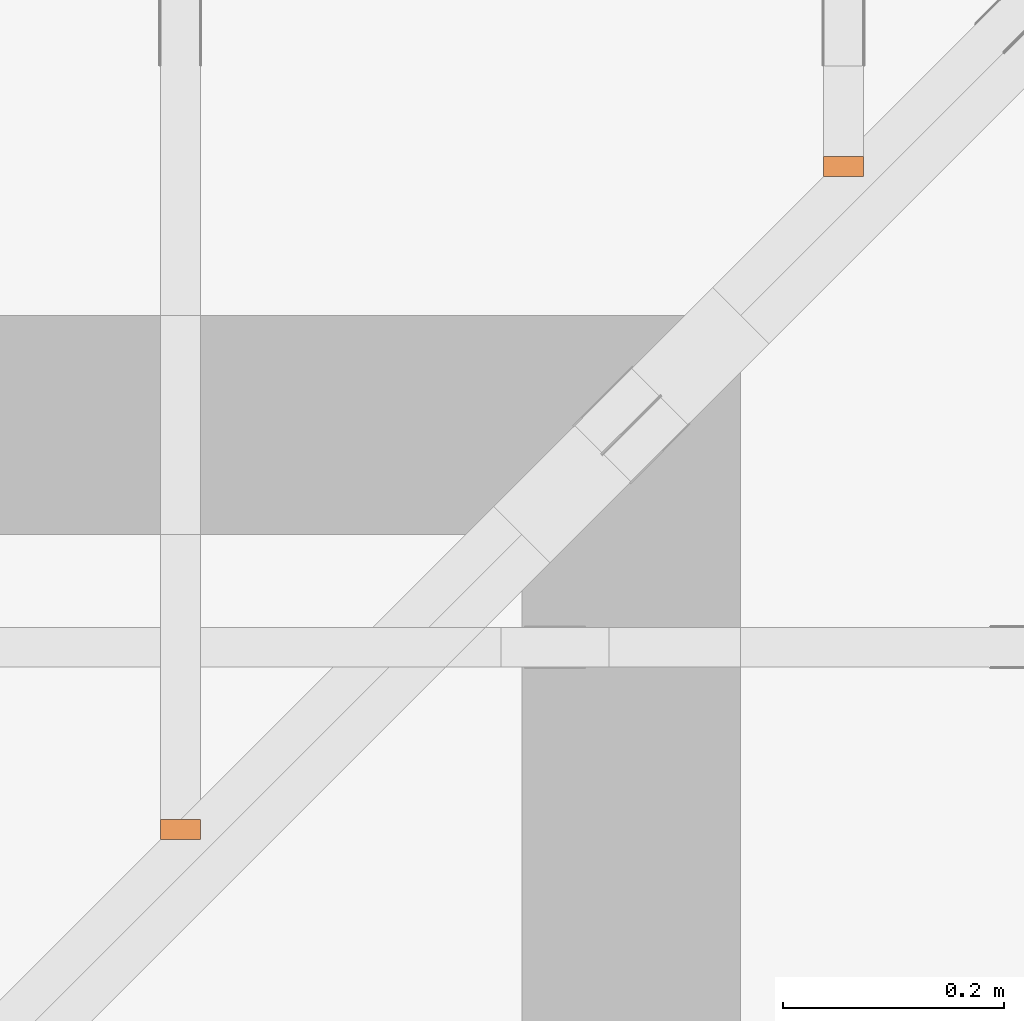
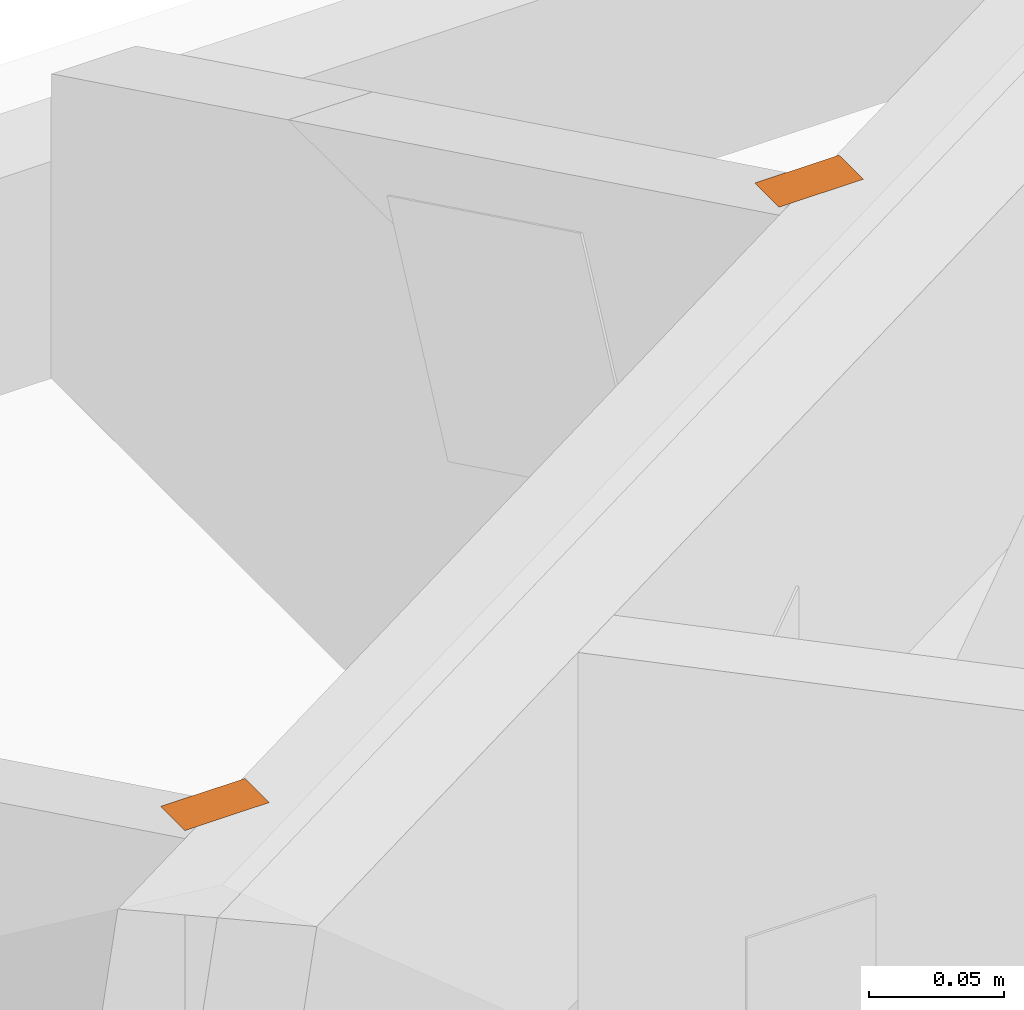
# One storey, part 158 of 159: 2 proxies, 2 elements without a shape of their own.
"""IFC2X3 building model written with IfcOpenShell, lengths in millimetres."""

from ifc_helpers import new_model, si_unit, frame, origin, origin_with_axes, origin_2d, place, context, project, spatial, open_shell, surface_model, element, aggregate, save


model = new_model("IFC2X3")

# Units and contexts
model_context = context("Model", 3, precision=1e-05, world=origin())
plan_context = context("Plan", 2, precision=1e-05, world=origin_2d())
ifc_project = project(units=[si_unit("LENGTHUNIT", "METRE", prefix="MILLI"), si_unit("AREAUNIT", "SQUARE_METRE"), si_unit("VOLUMEUNIT", "CUBIC_METRE"), si_unit("SOLIDANGLEUNIT", "STERADIAN"), si_unit("PLANEANGLEUNIT", "RADIAN"), si_unit("MASSUNIT", "GRAM"), si_unit("TIMEUNIT", "SECOND"), si_unit("THERMODYNAMICTEMPERATUREUNIT", "DEGREE_CELSIUS"), si_unit("LUMINOUSINTENSITYUNIT", "LUMEN")], contexts=[model_context, plan_context])

# Site, building, storey
site_placement = place(None, origin_with_axes())
site = spatial("IfcSite", under=ifc_project, at=site_placement, CompositionType="ELEMENT")
building_placement = place(site_placement, origin_with_axes())
building = spatial("IfcBuilding", under=site, at=building_placement, Name="Plan 1", CompositionType="ELEMENT")
storey_placement = place(building_placement, origin_with_axes())
storey = spatial("IfcBuildingStorey", under=building, at=storey_placement, Name="Etasje 1", CompositionType="ELEMENT", Elevation=0.0)

# Assembly, proxy
assembly_1_placement = place(storey_placement, frame((19875.02226140475, 9663.999999999993, 1.1021457184401395e-15), z_axis=(-1.0, 1.836909530733566e-16, 6.123031769111886e-17), x_axis=(-1.836909530733566e-16, -1.0, 0.0)))
assembly_1 = element("IfcElementAssembly", 1, at=assembly_1_placement, inside=storey, Name="S22 (57)", AssemblyPlace="FACTORY", PredefinedType="TRUSS")
proxy_1_placement = place(assembly_1_placement, frame((1120.078713451298, 696.272908246534, 0.0), z_axis=(0.0, 1.0, 0.0), x_axis=(1.0, 0.0, 0.0)))
proxy_1 = element("IfcBuildingElementProxy", 2, at=proxy_1_placement, Name="2", context=model_context, shape_type="SurfaceModel", body=[
    surface_model("IfcFaceBasedSurfaceModel", [(-2.2737367544323206e-12, 0.0, 0.0), (17.999999999548436, 0.0, 0.0), (17.999999999548436, 36.0, 0.0), (-2.2737367544323206e-12, 36.0, 0.0)], [open_shell([[[0, 1, 2, 3]]], orient=[[False]])]),
])
aggregate(assembly_1, [proxy_1])

assembly_2_placement = place(storey_placement, frame((20475.02226140475, 9663.999999999289, 1.1021457184401395e-15), z_axis=(-1.0, -3.9144503800490546e-11, 6.123031769111886e-17), x_axis=(3.9144503800490546e-11, -1.0, 0.0)))
assembly_2 = element("IfcElementAssembly", 3, at=assembly_2_placement, inside=storey, Name="S21 (1)", AssemblyPlace="FACTORY", PredefinedType="TRUSS")
proxy_2_placement = place(assembly_2_placement, frame((520.0787134508496, 403.6333551070238, 0.0), z_axis=(0.0, 1.0, 0.0), x_axis=(1.0, 0.0, 0.0)))
proxy_2 = element("IfcBuildingElementProxy", 4, at=proxy_2_placement, Name="2", context=model_context, shape_type="SurfaceModel", body=[
    surface_model("IfcFaceBasedSurfaceModel", [(-3.183231456205249e-12, 0.0, 0.0), (17.999999999978627, 3.637978807091713e-12, 0.0), (17.999999999978627, 36.000000000007276, 0.0), (-3.183231456205249e-12, 36.00000000000364, 0.0)], [open_shell([[[0, 1, 2, 3]]], orient=[[False]])]),
])
aggregate(assembly_2, [proxy_2])

save(model, "model.ifc")
